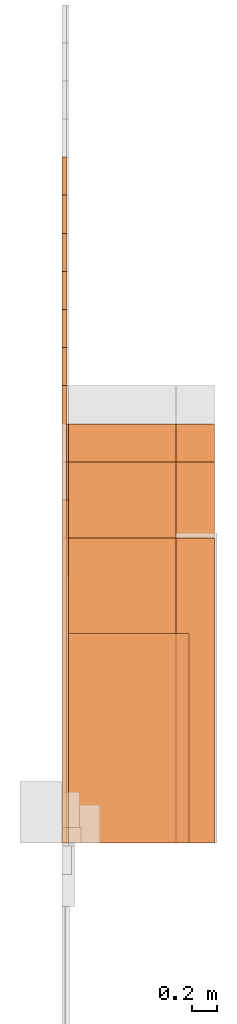
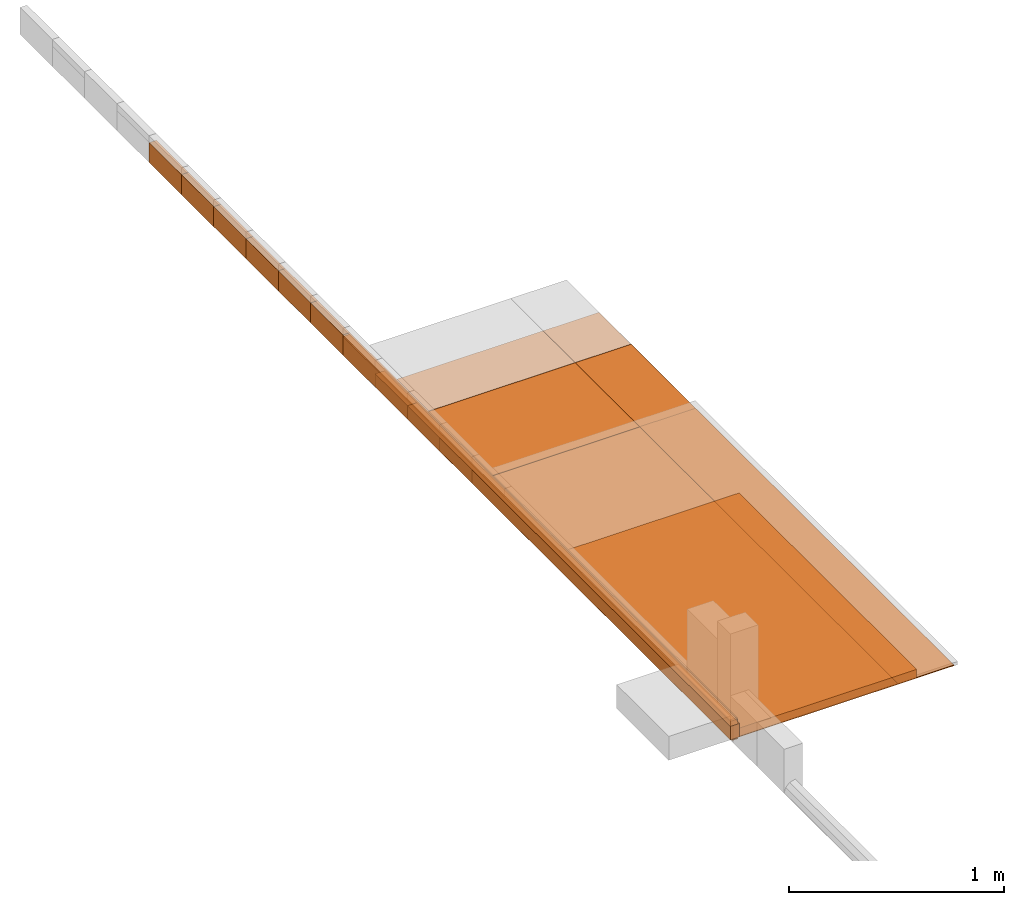
# Not in any storey, part 2 of 5: 26 proxies.
"""IFC4 model written with IfcOpenShell, lengths in metres."""

from ifc_helpers import new_model, entity, si_unit, converted_unit, direction, origin_with_axes, place, context, subcontext, project, faceted_brep, element, save


model = new_model("IFC4")

# Units and contexts
model_context = context("Model", 3, precision=1e-05, world=origin_with_axes(), true_north=direction((0.0, 1.0)))
body_context = subcontext(model_context, "Body", "Model", "MODEL_VIEW")
ifc_project = project(units=[si_unit("LENGTHUNIT", "METRE"), si_unit("AREAUNIT", "SQUARE_METRE"), si_unit("VOLUMEUNIT", "CUBIC_METRE"), converted_unit("PLANEANGLEUNIT", "DEGREE", entity("IfcPlaneAngleMeasure", 0.017453292519943295), si_unit("PLANEANGLEUNIT", "RADIAN"), dimensions=[0, 0, 0, 0, 0, 0, 0])], contexts=[model_context])

# Proxies
proxy_1_placement = place(None, origin_with_axes())
element("IfcBuildingElementProxy", 1, at=proxy_1_placement, Name="Timber 114x38x3600", context=body_context, shape_type="Brep", body=[
    faceted_brep([(0.0, 3.6, 0.0), (0.0, 3.6, 0.114), (0.038, 3.6, 0.114), (0.038, 3.6, 0.0), (0.038, 3.6, 0.0), (0.038, 3.6, 0.114), (0.038, 0.0, 0.114), (0.038, 0.0, 0.0), (0.038, 0.0, 0.0), (0.038, 0.0, 0.114), (0.0, 0.0, 0.114), (0.0, 0.0, 0.0), (0.0, 0.0, 0.0), (0.0, 0.0, 0.114), (0.0, 3.6, 0.114), (0.0, 3.6, 0.0), (0.038, 0.0, 0.0), (0.0, 0.0, 0.0), (0.0, 3.6, 0.0), (0.038, 3.6, 0.0), (0.038, 3.6, 0.114), (0.0, 3.6, 0.114), (0.0, 0.0, 0.114), (0.038, 0.0, 0.114)], [[[0, 1, 2, 3]], [[4, 5, 6, 7]], [[8, 9, 10, 11]], [[12, 13, 14, 15]], [[16, 17, 18, 19]], [[20, 21, 22, 23]]]),
])
proxy_2_placement = place(None, origin_with_axes())
element("IfcBuildingElementProxy", 2, at=proxy_2_placement, Name="Timber 114x38x3900", context=body_context, shape_type="Brep", body=[
    faceted_brep([(0.038, 0.0, 0.0), (0.038, 0.0, 0.114), (0.0, 0.0, 0.114), (0.0, 0.0, 0.0), (0.038, 3.9, 0.0), (0.038, 3.9, 0.114), (0.038, 0.0, 0.114), (0.038, 0.0, 0.0), (0.0, 3.9, 0.0), (0.0, 3.9, 0.114), (0.038, 3.9, 0.114), (0.038, 3.9, 0.0), (0.0, 0.0, 0.0), (0.0, 0.0, 0.114), (0.0, 3.9, 0.114), (0.0, 3.9, 0.0), (0.0, 3.9, 0.0), (0.038, 3.9, 0.0), (0.038, 0.0, 0.0), (0.0, 0.0, 0.0), (0.0, 0.0, 0.114), (0.038, 0.0, 0.114), (0.038, 3.9, 0.114), (0.0, 3.9, 0.114)], [[[0, 1, 2, 3]], [[4, 5, 6, 7]], [[8, 9, 10, 11]], [[12, 13, 14, 15]], [[16, 17, 18, 19]], [[20, 21, 22, 23]]]),
])
proxy_3_placement = place(None, origin_with_axes())
element("IfcBuildingElementProxy", 3, at=proxy_3_placement, Name="Timber 114x38x4200", context=body_context, shape_type="Brep", body=[
    faceted_brep([(0.0, 4.2, 0.0), (0.0, 4.2, 0.114), (0.038, 4.2, 0.114), (0.038, 4.2, 0.0), (0.038, 4.2, 0.0), (0.038, 4.2, 0.114), (0.038, 0.0, 0.114), (0.038, 0.0, 0.0), (0.038, 0.0, 0.0), (0.038, 0.0, 0.114), (0.0, 0.0, 0.114), (0.0, 0.0, 0.0), (0.0, 0.0, 0.0), (0.0, 0.0, 0.114), (0.0, 4.2, 0.114), (0.0, 4.2, 0.0), (0.038, 0.0, 0.0), (0.0, 0.0, 0.0), (0.0, 4.2, 0.0), (0.038, 4.2, 0.0), (0.038, 4.2, 0.114), (0.0, 4.2, 0.114), (0.0, 0.0, 0.114), (0.038, 0.0, 0.114)], [[[0, 1, 2, 3]], [[4, 5, 6, 7]], [[8, 9, 10, 11]], [[12, 13, 14, 15]], [[16, 17, 18, 19]], [[20, 21, 22, 23]]]),
])
proxy_4_placement = place(None, origin_with_axes())
element("IfcBuildingElementProxy", 4, at=proxy_4_placement, Name="Timber 114x38x4500", context=body_context, shape_type="Brep", body=[
    faceted_brep([(0.038, 0.0, 0.0), (0.038, 0.0, 0.114), (0.0, 0.0, 0.114), (0.0, 0.0, 0.0), (0.038, 4.5, 0.0), (0.038, 4.5, 0.114), (0.038, 0.0, 0.114), (0.038, 0.0, 0.0), (0.0, 4.5, 0.0), (0.0, 4.5, 0.114), (0.038, 4.5, 0.114), (0.038, 4.5, 0.0), (0.0, 0.0, 0.0), (0.0, 0.0, 0.114), (0.0, 4.5, 0.114), (0.0, 4.5, 0.0), (0.0, 4.5, 0.0), (0.038, 4.5, 0.0), (0.038, 0.0, 0.0), (0.0, 0.0, 0.0), (0.0, 0.0, 0.114), (0.038, 0.0, 0.114), (0.038, 4.5, 0.114), (0.0, 4.5, 0.114)], [[[0, 1, 2, 3]], [[4, 5, 6, 7]], [[8, 9, 10, 11]], [[12, 13, 14, 15]], [[16, 17, 18, 19]], [[20, 21, 22, 23]]]),
])
proxy_5_placement = place(None, origin_with_axes())
element("IfcBuildingElementProxy", 5, at=proxy_5_placement, Name="Timber 114x38x4800", context=body_context, shape_type="Brep", body=[
    faceted_brep([(0.038, 0.0, 0.0), (0.038, 0.0, 0.114), (0.0, 0.0, 0.114), (0.0, 0.0, 0.0), (0.038, 4.8, 0.0), (0.038, 4.8, 0.114), (0.038, 0.0, 0.114), (0.038, 0.0, 0.0), (0.0, 4.8, 0.0), (0.0, 4.8, 0.114), (0.038, 4.8, 0.114), (0.038, 4.8, 0.0), (0.0, 0.0, 0.0), (0.0, 0.0, 0.114), (0.0, 4.8, 0.114), (0.0, 4.8, 0.0), (0.0, 4.8, 0.0), (0.038, 4.8, 0.0), (0.038, 0.0, 0.0), (0.0, 0.0, 0.0), (0.0, 0.0, 0.114), (0.038, 0.0, 0.114), (0.038, 4.8, 0.114), (0.0, 4.8, 0.114)], [[[0, 1, 2, 3]], [[4, 5, 6, 7]], [[8, 9, 10, 11]], [[12, 13, 14, 15]], [[16, 17, 18, 19]], [[20, 21, 22, 23]]]),
])
proxy_6_placement = place(None, origin_with_axes())
element("IfcBuildingElementProxy", 6, at=proxy_6_placement, Name="Timber 114x38x5100", context=body_context, shape_type="Brep", body=[
    faceted_brep([(0.038, 0.0, 0.0), (0.038, 0.0, 0.114), (0.0, 0.0, 0.114), (0.0, 0.0, 0.0), (0.038, 5.1, 0.0), (0.038, 5.1, 0.114), (0.038, 0.0, 0.114), (0.038, 0.0, 0.0), (0.0, 5.1, 0.0), (0.0, 5.1, 0.114), (0.038, 5.1, 0.114), (0.038, 5.1, 0.0), (0.0, 0.0, 0.0), (0.0, 0.0, 0.114), (0.0, 5.1, 0.114), (0.0, 5.1, 0.0), (0.0, 5.1, 0.0), (0.038, 5.1, 0.0), (0.038, 0.0, 0.0), (0.0, 0.0, 0.0), (0.0, 0.0, 0.114), (0.038, 0.0, 0.114), (0.038, 5.1, 0.114), (0.0, 5.1, 0.114)], [[[0, 1, 2, 3]], [[4, 5, 6, 7]], [[8, 9, 10, 11]], [[12, 13, 14, 15]], [[16, 17, 18, 19]], [[20, 21, 22, 23]]]),
])
proxy_7_placement = place(None, origin_with_axes())
element("IfcBuildingElementProxy", 7, at=proxy_7_placement, Name="Timber 114x38x5400", context=body_context, shape_type="Brep", body=[
    faceted_brep([(0.038, 0.0, 0.0), (0.038, 0.0, 0.114), (0.0, 0.0, 0.114), (0.0, 0.0, 0.0), (0.038, 5.4, 0.0), (0.038, 5.4, 0.114), (0.038, 0.0, 0.114), (0.038, 0.0, 0.0), (0.0, 5.4, 0.0), (0.0, 5.4, 0.114), (0.038, 5.4, 0.114), (0.038, 5.4, 0.0), (0.0, 0.0, 0.0), (0.0, 0.0, 0.114), (0.0, 5.4, 0.114), (0.0, 5.4, 0.0), (0.0, 5.4, 0.0), (0.038, 5.4, 0.0), (0.038, 0.0, 0.0), (0.0, 0.0, 0.0), (0.0, 0.0, 0.114), (0.038, 0.0, 0.114), (0.038, 5.4, 0.114), (0.0, 5.4, 0.114)], [[[0, 1, 2, 3]], [[4, 5, 6, 7]], [[8, 9, 10, 11]], [[12, 13, 14, 15]], [[16, 17, 18, 19]], [[20, 21, 22, 23]]]),
])
proxy_8_placement = place(None, origin_with_axes())
element("IfcBuildingElementProxy", 8, at=proxy_8_placement, Name="Timber 38x105x3600", context=body_context, shape_type="Brep", body=[
    faceted_brep([(0.0, 3.6, 0.0), (0.0, 3.6, 0.105), (0.038, 3.6, 0.105), (0.038, 3.6, 0.0), (0.038, 3.6, 0.0), (0.038, 3.6, 0.105), (0.038, 0.0, 0.105), (0.038, 0.0, 0.0), (0.038, 0.0, 0.0), (0.038, 0.0, 0.105), (0.0, 0.0, 0.105), (0.0, 0.0, 0.0), (0.0, 0.0, 0.0), (0.0, 0.0, 0.105), (0.0, 3.6, 0.105), (0.0, 3.6, 0.0), (0.038, 0.0, 0.0), (0.0, 0.0, 0.0), (0.0, 3.6, 0.0), (0.038, 3.6, 0.0), (0.038, 3.6, 0.105), (0.0, 3.6, 0.105), (0.0, 0.0, 0.105), (0.038, 0.0, 0.105)], [[[0, 1, 2, 3]], [[4, 5, 6, 7]], [[8, 9, 10, 11]], [[12, 13, 14, 15]], [[16, 17, 18, 19]], [[20, 21, 22, 23]]]),
])
proxy_9_placement = place(None, origin_with_axes())
element("IfcBuildingElementProxy", 9, at=proxy_9_placement, Name="Timber 50x76x2400", context=body_context, shape_type="Brep", body=[
    faceted_brep([(0.0, 2.4, 0.0), (0.0, 2.4, 0.076), (0.05, 2.4, 0.076), (0.05, 2.4, 0.0), (0.05, 2.4, 0.0), (0.05, 2.4, 0.076), (0.05, 0.0, 0.076), (0.05, 0.0, 0.0), (0.05, 0.0, 0.0), (0.05, 0.0, 0.076), (0.0, 0.0, 0.076), (0.0, 0.0, 0.0), (0.0, 0.0, 0.0), (0.0, 0.0, 0.076), (0.0, 2.4, 0.076), (0.0, 2.4, 0.0), (0.05, 0.0, 0.0), (0.0, 0.0, 0.0), (0.0, 2.4, 0.0), (0.05, 2.4, 0.0), (0.05, 2.4, 0.076), (0.0, 2.4, 0.076), (0.0, 0.0, 0.076), (0.05, 0.0, 0.076)], [[[0, 1, 2, 3]], [[4, 5, 6, 7]], [[8, 9, 10, 11]], [[12, 13, 14, 15]], [[16, 17, 18, 19]], [[20, 21, 22, 23]]]),
])
proxy_10_placement = place(None, origin_with_axes())
element("IfcBuildingElementProxy", 10, at=proxy_10_placement, Name="Timber 50x76x2700", context=body_context, shape_type="Brep", body=[
    faceted_brep([(0.0, 2.7, 0.0), (0.0, 2.7, 0.076), (0.05, 2.7, 0.076), (0.05, 2.7, 0.0), (0.05, 2.7, 0.0), (0.05, 2.7, 0.076), (0.05, 0.0, 0.076), (0.05, 0.0, 0.0), (0.05, 0.0, 0.0), (0.05, 0.0, 0.076), (0.0, 0.0, 0.076), (0.0, 0.0, 0.0), (0.0, 0.0, 0.0), (0.0, 0.0, 0.076), (0.0, 2.7, 0.076), (0.0, 2.7, 0.0), (0.05, 0.0, 0.0), (0.0, 0.0, 0.0), (0.0, 2.7, 0.0), (0.05, 2.7, 0.0), (0.05, 2.7, 0.076), (0.0, 2.7, 0.076), (0.0, 0.0, 0.076), (0.05, 0.0, 0.076)], [[[0, 1, 2, 3]], [[4, 5, 6, 7]], [[8, 9, 10, 11]], [[12, 13, 14, 15]], [[16, 17, 18, 19]], [[20, 21, 22, 23]]]),
])
proxy_11_placement = place(None, origin_with_axes())
element("IfcBuildingElementProxy", 11, at=proxy_11_placement, Name="Timber 50x76x3000", context=body_context, shape_type="Brep", body=[
    faceted_brep([(0.0, 3.0, 0.0), (0.0, 3.0, 0.076), (0.05, 3.0, 0.076), (0.05, 3.0, 0.0), (0.05, 3.0, 0.0), (0.05, 3.0, 0.076), (0.05, 0.0, 0.076), (0.05, 0.0, 0.0), (0.05, 0.0, 0.0), (0.05, 0.0, 0.076), (0.0, 0.0, 0.076), (0.0, 0.0, 0.0), (0.0, 0.0, 0.0), (0.0, 0.0, 0.076), (0.0, 3.0, 0.076), (0.0, 3.0, 0.0), (0.05, 0.0, 0.0), (0.0, 0.0, 0.0), (0.0, 3.0, 0.0), (0.05, 3.0, 0.0), (0.05, 3.0, 0.076), (0.0, 3.0, 0.076), (0.0, 0.0, 0.076), (0.05, 0.0, 0.076)], [[[0, 1, 2, 3]], [[4, 5, 6, 7]], [[8, 9, 10, 11]], [[12, 13, 14, 15]], [[16, 17, 18, 19]], [[20, 21, 22, 23]]]),
])
proxy_12_placement = place(None, origin_with_axes())
element("IfcBuildingElementProxy", 12, at=proxy_12_placement, Name="Timber 50x76x3300", context=body_context, shape_type="Brep", body=[
    faceted_brep([(0.05, 0.0, 0.0), (0.05, 0.0, 0.076), (0.0, 0.0, 0.076), (0.0, 0.0, 0.0), (0.05, 3.3, 0.0), (0.05, 3.3, 0.076), (0.05, 0.0, 0.076), (0.05, 0.0, 0.0), (0.0, 3.3, 0.0), (0.0, 3.3, 0.076), (0.05, 3.3, 0.076), (0.05, 3.3, 0.0), (0.0, 0.0, 0.0), (0.0, 0.0, 0.076), (0.0, 3.3, 0.076), (0.0, 3.3, 0.0), (0.0, 3.3, 0.0), (0.05, 3.3, 0.0), (0.05, 0.0, 0.0), (0.0, 0.0, 0.0), (0.0, 0.0, 0.076), (0.05, 0.0, 0.076), (0.05, 3.3, 0.076), (0.0, 3.3, 0.076)], [[[0, 1, 2, 3]], [[4, 5, 6, 7]], [[8, 9, 10, 11]], [[12, 13, 14, 15]], [[16, 17, 18, 19]], [[20, 21, 22, 23]]]),
])
proxy_13_placement = place(None, origin_with_axes())
element("IfcBuildingElementProxy", 13, at=proxy_13_placement, Name="900x2400x4", context=body_context, shape_type="Brep", body=[
    faceted_brep([(0.9, 0.0, 0.0), (0.9, 0.0, 0.004), (0.0, 0.0, 0.004), (0.0, 0.0, 0.0), (0.9, 2.4, 0.0), (0.9, 2.4, 0.004), (0.9, 0.0, 0.004), (0.9, 0.0, 0.0), (0.0, 2.4, 0.0), (0.0, 2.4, 0.004), (0.9, 2.4, 0.004), (0.9, 2.4, 0.0), (0.0, 0.0, 0.0), (0.0, 0.0, 0.004), (0.0, 2.4, 0.004), (0.0, 2.4, 0.0), (0.0, 2.4, 0.0), (0.9, 2.4, 0.0), (0.9, 0.0, 0.0), (0.0, 0.0, 0.0), (0.0, 0.0, 0.004), (0.9, 0.0, 0.004), (0.9, 2.4, 0.004), (0.0, 2.4, 0.004)], [[[0, 1, 2, 3]], [[4, 5, 6, 7]], [[8, 9, 10, 11]], [[12, 13, 14, 15]], [[16, 17, 18, 19]], [[20, 21, 22, 23]]]),
])
proxy_14_placement = place(None, origin_with_axes())
element("IfcBuildingElementProxy", 14, at=proxy_14_placement, Name="900x3000x4", context=body_context, shape_type="Brep", body=[
    faceted_brep([(0.9, 0.0, 0.0), (0.9, 0.0, 0.004), (0.0, 0.0, 0.004), (0.0, 0.0, 0.0), (0.9, 3.0, 0.0), (0.9, 3.0, 0.004), (0.9, 0.0, 0.004), (0.9, 0.0, 0.0), (0.0, 3.0, 0.0), (0.0, 3.0, 0.004), (0.9, 3.0, 0.004), (0.9, 3.0, 0.0), (0.0, 0.0, 0.0), (0.0, 0.0, 0.004), (0.0, 3.0, 0.004), (0.0, 3.0, 0.0), (0.0, 3.0, 0.0), (0.9, 3.0, 0.0), (0.9, 0.0, 0.0), (0.0, 0.0, 0.0), (0.0, 0.0, 0.004), (0.9, 0.0, 0.004), (0.9, 3.0, 0.004), (0.0, 3.0, 0.004)], [[[0, 1, 2, 3]], [[4, 5, 6, 7]], [[8, 9, 10, 11]], [[12, 13, 14, 15]], [[16, 17, 18, 19]], [[20, 21, 22, 23]]]),
])
proxy_15_placement = place(None, origin_with_axes())
element("IfcBuildingElementProxy", 15, at=proxy_15_placement, Name="900x3300x4", context=body_context, shape_type="Brep", body=[
    faceted_brep([(0.9, 0.0, 0.0), (0.9, 0.0, 0.004), (0.0, 0.0, 0.004), (0.0, 0.0, 0.0), (0.9, 3.3, 0.0), (0.9, 3.3, 0.004), (0.9, 0.0, 0.004), (0.9, 0.0, 0.0), (0.0, 3.3, 0.0), (0.0, 3.3, 0.004), (0.9, 3.3, 0.004), (0.9, 3.3, 0.0), (0.0, 0.0, 0.0), (0.0, 0.0, 0.004), (0.0, 3.3, 0.004), (0.0, 3.3, 0.0), (0.0, 3.3, 0.0), (0.9, 3.3, 0.0), (0.9, 0.0, 0.0), (0.0, 0.0, 0.0), (0.0, 0.0, 0.004), (0.9, 0.0, 0.004), (0.9, 3.3, 0.004), (0.0, 3.3, 0.004)], [[[0, 1, 2, 3]], [[4, 5, 6, 7]], [[8, 9, 10, 11]], [[12, 13, 14, 15]], [[16, 17, 18, 19]], [[20, 21, 22, 23]]]),
])
proxy_16_placement = place(None, origin_with_axes())
element("IfcBuildingElementProxy", 16, at=proxy_16_placement, Name="1200x2400x4", context=body_context, shape_type="Brep", body=[
    faceted_brep([(1.2, 0.0, 0.0), (1.2, 0.0, 0.004), (0.0, 0.0, 0.004), (0.0, 0.0, 0.0), (1.2, 2.4, 0.0), (1.2, 2.4, 0.004), (1.2, 0.0, 0.004), (1.2, 0.0, 0.0), (0.0, 2.4, 0.0), (0.0, 2.4, 0.004), (1.2, 2.4, 0.004), (1.2, 2.4, 0.0), (0.0, 0.0, 0.0), (0.0, 0.0, 0.004), (0.0, 2.4, 0.004), (0.0, 2.4, 0.0), (0.0, 2.4, 0.0), (1.2, 2.4, 0.0), (1.2, 0.0, 0.0), (0.0, 0.0, 0.0), (0.0, 0.0, 0.004), (1.2, 0.0, 0.004), (1.2, 2.4, 0.004), (0.0, 2.4, 0.004)], [[[0, 1, 2, 3]], [[4, 5, 6, 7]], [[8, 9, 10, 11]], [[12, 13, 14, 15]], [[16, 17, 18, 19]], [[20, 21, 22, 23]]]),
])
proxy_17_placement = place(None, origin_with_axes())
element("IfcBuildingElementProxy", 17, at=proxy_17_placement, Name="1200x3000x4", context=body_context, shape_type="Brep", body=[
    faceted_brep([(1.2, 0.0, 0.0), (1.2, 0.0, 0.004), (0.0, 0.0, 0.004), (0.0, 0.0, 0.0), (1.2, 3.0, 0.0), (1.2, 3.0, 0.004), (1.2, 0.0, 0.004), (1.2, 0.0, 0.0), (0.0, 3.0, 0.0), (0.0, 3.0, 0.004), (1.2, 3.0, 0.004), (1.2, 3.0, 0.0), (0.0, 0.0, 0.0), (0.0, 0.0, 0.004), (0.0, 3.0, 0.004), (0.0, 3.0, 0.0), (0.0, 3.0, 0.0), (1.2, 3.0, 0.0), (1.2, 0.0, 0.0), (0.0, 0.0, 0.0), (0.0, 0.0, 0.004), (1.2, 0.0, 0.004), (1.2, 3.0, 0.004), (0.0, 3.0, 0.004)], [[[0, 1, 2, 3]], [[4, 5, 6, 7]], [[8, 9, 10, 11]], [[12, 13, 14, 15]], [[16, 17, 18, 19]], [[20, 21, 22, 23]]]),
])
proxy_18_placement = place(None, origin_with_axes())
element("IfcBuildingElementProxy", 18, at=proxy_18_placement, Name="1200x3300x4", context=body_context, shape_type="Brep", body=[
    faceted_brep([(1.2, 0.0, 0.0), (1.2, 0.0, 0.004), (0.0, 0.0, 0.004), (0.0, 0.0, 0.0), (1.2, 3.3, 0.0), (1.2, 3.3, 0.004), (1.2, 0.0, 0.004), (1.2, 0.0, 0.0), (0.0, 3.3, 0.0), (0.0, 3.3, 0.004), (1.2, 3.3, 0.004), (1.2, 3.3, 0.0), (0.0, 0.0, 0.0), (0.0, 0.0, 0.004), (0.0, 3.3, 0.004), (0.0, 3.3, 0.0), (0.0, 3.3, 0.0), (1.2, 3.3, 0.0), (1.2, 0.0, 0.0), (0.0, 0.0, 0.0), (0.0, 0.0, 0.004), (1.2, 0.0, 0.004), (1.2, 3.3, 0.004), (0.0, 3.3, 0.004)], [[[0, 1, 2, 3]], [[4, 5, 6, 7]], [[8, 9, 10, 11]], [[12, 13, 14, 15]], [[16, 17, 18, 19]], [[20, 21, 22, 23]]]),
])
proxy_19_placement = place(None, origin_with_axes())
element("IfcBuildingElementProxy", 19, at=proxy_19_placement, Name="900x3000x6", context=body_context, shape_type="Brep", body=[
    faceted_brep([(0.9, 0.0, 0.0), (0.9, 0.0, 0.006), (0.0, 0.0, 0.006), (0.0, 0.0, 0.0), (0.9, 3.0, 0.0), (0.9, 3.0, 0.006), (0.9, 0.0, 0.006), (0.9, 0.0, 0.0), (0.0, 3.0, 0.0), (0.0, 3.0, 0.006), (0.9, 3.0, 0.006), (0.9, 3.0, 0.0), (0.0, 0.0, 0.0), (0.0, 0.0, 0.006), (0.0, 3.0, 0.006), (0.0, 3.0, 0.0), (0.0, 3.0, 0.0), (0.9, 3.0, 0.0), (0.9, 0.0, 0.0), (0.0, 0.0, 0.0), (0.0, 0.0, 0.006), (0.9, 0.0, 0.006), (0.9, 3.0, 0.006), (0.0, 3.0, 0.006)], [[[0, 1, 2, 3]], [[4, 5, 6, 7]], [[8, 9, 10, 11]], [[12, 13, 14, 15]], [[16, 17, 18, 19]], [[20, 21, 22, 23]]]),
])
proxy_20_placement = place(None, origin_with_axes())
element("IfcBuildingElementProxy", 20, at=proxy_20_placement, Name="900x2400x6", context=body_context, shape_type="Brep", body=[
    faceted_brep([(0.9, 0.0, 0.0), (0.9, 0.0, 0.006), (0.0, 0.0, 0.006), (0.0, 0.0, 0.0), (0.9, 2.4, 0.0), (0.9, 2.4, 0.006), (0.9, 0.0, 0.006), (0.9, 0.0, 0.0), (0.0, 2.4, 0.0), (0.0, 2.4, 0.006), (0.9, 2.4, 0.006), (0.9, 2.4, 0.0), (0.0, 0.0, 0.0), (0.0, 0.0, 0.006), (0.0, 2.4, 0.006), (0.0, 2.4, 0.0), (0.0, 2.4, 0.0), (0.9, 2.4, 0.0), (0.9, 0.0, 0.0), (0.0, 0.0, 0.0), (0.0, 0.0, 0.006), (0.9, 0.0, 0.006), (0.9, 2.4, 0.006), (0.0, 2.4, 0.006)], [[[0, 1, 2, 3]], [[4, 5, 6, 7]], [[8, 9, 10, 11]], [[12, 13, 14, 15]], [[16, 17, 18, 19]], [[20, 21, 22, 23]]]),
])
proxy_21_placement = place(None, origin_with_axes())
element("IfcBuildingElementProxy", 21, at=proxy_21_placement, Name="1200x2400x6", context=body_context, shape_type="Brep", body=[
    faceted_brep([(1.2, 0.0, 0.0), (1.2, 0.0, 0.006), (0.0, 0.0, 0.006), (0.0, 0.0, 0.0), (1.2, 2.4, 0.0), (1.2, 2.4, 0.006), (1.2, 0.0, 0.006), (1.2, 0.0, 0.0), (0.0, 2.4, 0.0), (0.0, 2.4, 0.006), (1.2, 2.4, 0.006), (1.2, 2.4, 0.0), (0.0, 0.0, 0.0), (0.0, 0.0, 0.006), (0.0, 2.4, 0.006), (0.0, 2.4, 0.0), (0.0, 2.4, 0.0), (1.2, 2.4, 0.0), (1.2, 0.0, 0.0), (0.0, 0.0, 0.0), (0.0, 0.0, 0.006), (1.2, 0.0, 0.006), (1.2, 2.4, 0.006), (0.0, 2.4, 0.006)], [[[0, 1, 2, 3]], [[4, 5, 6, 7]], [[8, 9, 10, 11]], [[12, 13, 14, 15]], [[16, 17, 18, 19]], [[20, 21, 22, 23]]]),
])
proxy_22_placement = place(None, origin_with_axes())
element("IfcBuildingElementProxy", 22, at=proxy_22_placement, Name="1200x3000x6", context=body_context, shape_type="Brep", body=[
    faceted_brep([(1.2, 0.0, 0.0), (1.2, 0.0, 0.006), (0.0, 0.0, 0.006), (0.0, 0.0, 0.0), (1.2, 3.0, 0.0), (1.2, 3.0, 0.006), (1.2, 0.0, 0.006), (1.2, 0.0, 0.0), (0.0, 3.0, 0.0), (0.0, 3.0, 0.006), (1.2, 3.0, 0.006), (1.2, 3.0, 0.0), (0.0, 0.0, 0.0), (0.0, 0.0, 0.006), (0.0, 3.0, 0.006), (0.0, 3.0, 0.0), (0.0, 3.0, 0.0), (1.2, 3.0, 0.0), (1.2, 0.0, 0.0), (0.0, 0.0, 0.0), (0.0, 0.0, 0.006), (1.2, 0.0, 0.006), (1.2, 3.0, 0.006), (0.0, 3.0, 0.006)], [[[0, 1, 2, 3]], [[4, 5, 6, 7]], [[8, 9, 10, 11]], [[12, 13, 14, 15]], [[16, 17, 18, 19]], [[20, 21, 22, 23]]]),
])
proxy_23_placement = place(None, origin_with_axes())
element("IfcBuildingElementProxy", 23, at=proxy_23_placement, Name="Solar panel 1650x1000x5", context=body_context, shape_type="Brep", body=[
    faceted_brep([(1.0, 0.0, 0.0), (1.0, 0.0, 0.05), (0.0, 0.0, 0.05), (0.0, 0.0, 0.0), (1.0, 1.65, 0.0), (1.0, 1.65, 0.05), (1.0, 0.0, 0.05), (1.0, 0.0, 0.0), (0.0, 1.65, 0.0), (0.0, 1.65, 0.05), (1.0, 1.65, 0.05), (1.0, 1.65, 0.0), (0.0, 0.0, 0.0), (0.0, 0.0, 0.05), (0.0, 1.65, 0.05), (0.0, 1.65, 0.0), (0.0, 1.65, 0.0), (1.0, 1.65, 0.0), (1.0, 0.0, 0.0), (0.0, 0.0, 0.0), (0.0, 0.0, 0.05), (1.0, 0.0, 0.05), (1.0, 1.65, 0.05), (0.0, 1.65, 0.05)], [[[0, 1, 2, 3]], [[4, 5, 6, 7]], [[8, 9, 10, 11]], [[12, 13, 14, 15]], [[16, 17, 18, 19]], [[20, 21, 22, 23]]]),
])
proxy_24_placement = place(None, origin_with_axes())
element("IfcBuildingElementProxy", 24, at=proxy_24_placement, Name="Strip 4x2700", context=body_context, shape_type="Brep", body=[
    faceted_brep([(0.025, 0.0, 0.0), (0.025, 2.7, 5.99520433297585e-16), (0.0, 2.7, 5.99520433297585e-16), (0.0, 0.0, 0.0), (0.025, 1.02140518265514e-18, -0.0046), (0.025, 2.7, -0.0045999999999994), (0.025, 2.7, 5.99520433297585e-16), (0.025, 0.0, 0.0), (0.01055, 1.02140518265514e-18, -0.0046), (0.01055, 2.7, -0.0045999999999994), (0.025, 2.7, -0.0045999999999994), (0.025, 1.02140518265514e-18, -0.0046), (0.01055, 1.13242748511766e-18, -0.0051), (0.01055, 2.7, -0.0050999999999994), (0.01055, 2.7, -0.0045999999999994), (0.01055, 1.02140518265514e-18, -0.0046), (0.03995, 1.13242748511766e-18, -0.0051), (0.03995, 2.7, -0.0050999999999994), (0.01055, 2.7, -0.0050999999999994), (0.01055, 1.13242748511766e-18, -0.0051), (0.03995, 1.02140518265514e-18, -0.0046), (0.03995, 2.7, -0.0045999999999994), (0.03995, 2.7, -0.0050999999999994), (0.03995, 1.13242748511766e-18, -0.0051), (0.0255, 1.02140518265514e-18, -0.0046), (0.0255, 2.7, -0.0045999999999994), (0.03995, 2.7, -0.0045999999999994), (0.03995, 1.02140518265514e-18, -0.0046), (0.0255, 0.0, 0.0), (0.0255, 2.7, 5.99520433297585e-16), (0.0255, 2.7, -0.0045999999999994), (0.0255, 1.02140518265514e-18, -0.0046), (0.0505, 0.0, 0.0), (0.0505, 2.7, 5.99520433297585e-16), (0.0255, 2.7, 5.99520433297585e-16), (0.0255, 0.0, 0.0), (0.0505, 6.66133814775094e-20, -0.0003), (0.0505, 2.7, -0.0002999999999994), (0.0505, 2.7, 5.99520433297585e-16), (0.0505, 0.0, 0.0), (0.0258, 6.66133814775094e-20, -0.0003), (0.0258, 2.7, -0.0002999999999994), (0.0505, 2.7, -0.0002999999999994), (0.0505, 6.66133814775094e-20, -0.0003), (0.0258, 9.54791801177635e-19, -0.0043), (0.0258, 2.7, -0.0042999999999994), (0.0258, 2.7, -0.0002999999999994), (0.0258, 6.66133814775094e-20, -0.0003), (0.04025, 9.54791801177635e-19, -0.0043), (0.04025, 2.7, -0.0042999999999994), (0.0258, 2.7, -0.0042999999999994), (0.0258, 9.54791801177635e-19, -0.0043), (0.04025, 1.19904086659517e-18, -0.0054), (0.04025, 2.7, -0.0053999999999994), (0.04025, 2.7, -0.0042999999999994), (0.04025, 9.54791801177635e-19, -0.0043), (0.01025, 1.19904086659517e-18, -0.0054), (0.01025, 2.7, -0.0053999999999994), (0.04025, 2.7, -0.0053999999999994), (0.04025, 1.19904086659517e-18, -0.0054), (0.01025, 9.54791801177635e-19, -0.0043), (0.01025, 2.7, -0.0042999999999994), (0.01025, 2.7, -0.0053999999999994), (0.01025, 1.19904086659517e-18, -0.0054), (0.0247, 9.54791801177635e-19, -0.0043), (0.0247, 2.7, -0.0042999999999994), (0.01025, 2.7, -0.0042999999999994), (0.01025, 9.54791801177635e-19, -0.0043), (0.0247, 6.66133814775094e-20, -0.0003), (0.0247, 2.7, -0.0002999999999994), (0.0247, 2.7, -0.0042999999999994), (0.0247, 9.54791801177635e-19, -0.0043), (0.0, 6.66133814775094e-20, -0.0003), (0.0, 2.7, -0.0002999999999994), (0.0247, 2.7, -0.0002999999999994), (0.0247, 6.66133814775094e-20, -0.0003), (0.0, 0.0, 0.0), (0.0, 2.7, 5.99520433297585e-16), (0.0, 2.7, -0.0002999999999994), (0.0, 6.66133814775094e-20, -0.0003), (0.0, 6.66133814775094e-20, -0.0003), (0.0247, 6.66133814775094e-20, -0.0003), (0.0247, 9.54791801177635e-19, -0.0043), (0.01025, 9.54791801177635e-19, -0.0043), (0.01025, 1.19904086659517e-18, -0.0054), (0.04025, 1.19904086659517e-18, -0.0054), (0.04025, 9.54791801177635e-19, -0.0043), (0.0258, 9.54791801177635e-19, -0.0043), (0.0258, 6.66133814775094e-20, -0.0003), (0.0505, 6.66133814775094e-20, -0.0003), (0.0505, 0.0, 0.0), (0.0255, 0.0, 0.0), (0.0255, 1.02140518265514e-18, -0.0046), (0.03995, 1.02140518265514e-18, -0.0046), (0.03995, 1.13242748511766e-18, -0.0051), (0.01055, 1.13242748511766e-18, -0.0051), (0.01055, 1.02140518265514e-18, -0.0046), (0.025, 1.02140518265514e-18, -0.0046), (0.025, 0.0, 0.0), (0.0, 0.0, 0.0), (0.0, 2.7, 5.99520433297585e-16), (0.025, 2.7, 5.99520433297585e-16), (0.025, 2.7, -0.0045999999999994), (0.01055, 2.7, -0.0045999999999994), (0.01055, 2.7, -0.0050999999999994), (0.03995, 2.7, -0.0050999999999994), (0.03995, 2.7, -0.0045999999999994), (0.0255, 2.7, -0.0045999999999994), (0.0255, 2.7, 5.99520433297585e-16), (0.0505, 2.7, 5.99520433297585e-16), (0.0505, 2.7, -0.0002999999999994), (0.0258, 2.7, -0.0002999999999994), (0.0258, 2.7, -0.0042999999999994), (0.04025, 2.7, -0.0042999999999994), (0.04025, 2.7, -0.0053999999999994), (0.01025, 2.7, -0.0053999999999994), (0.01025, 2.7, -0.0042999999999994), (0.0247, 2.7, -0.0042999999999994), (0.0247, 2.7, -0.0002999999999994), (0.0, 2.7, -0.0002999999999994)], [[[0, 1, 2, 3]], [[4, 5, 6, 7]], [[8, 9, 10, 11]], [[12, 13, 14, 15]], [[16, 17, 18, 19]], [[20, 21, 22, 23]], [[24, 25, 26, 27]], [[28, 29, 30, 31]], [[32, 33, 34, 35]], [[36, 37, 38, 39]], [[40, 41, 42, 43]], [[44, 45, 46, 47]], [[48, 49, 50, 51]], [[52, 53, 54, 55]], [[56, 57, 58, 59]], [[60, 61, 62, 63]], [[64, 65, 66, 67]], [[68, 69, 70, 71]], [[72, 73, 74, 75]], [[76, 77, 78, 79]], [[80, 81, 82, 83, 84, 85, 86, 87, 88, 89, 90, 91, 92, 93, 94, 95, 96, 97, 98, 99]], [[100, 101, 102, 103, 104, 105, 106, 107, 108, 109, 110, 111, 112, 113, 114, 115, 116, 117, 118, 119]]]),
])
proxy_25_placement = place(None, origin_with_axes())
element("IfcBuildingElementProxy", 25, at=proxy_25_placement, Name="Strip 4x3000", context=body_context, shape_type="Brep", body=[
    faceted_brep([(0.025, 0.0, 0.0), (0.025, 3.0, 6.66133814775094e-16), (0.0, 3.0, 6.66133814775094e-16), (0.0, 0.0, 0.0), (0.025, 1.02140518265514e-18, -0.0046), (0.025, 3.0, -0.00459999999999933), (0.025, 3.0, 6.66133814775094e-16), (0.025, 0.0, 0.0), (0.01055, 1.02140518265514e-18, -0.0046), (0.01055, 3.0, -0.00459999999999933), (0.025, 3.0, -0.00459999999999933), (0.025, 1.02140518265514e-18, -0.0046), (0.01055, 1.13242748511766e-18, -0.0051), (0.01055, 3.0, -0.00509999999999933), (0.01055, 3.0, -0.00459999999999933), (0.01055, 1.02140518265514e-18, -0.0046), (0.03995, 1.13242748511766e-18, -0.0051), (0.03995, 3.0, -0.00509999999999933), (0.01055, 3.0, -0.00509999999999933), (0.01055, 1.13242748511766e-18, -0.0051), (0.03995, 1.02140518265514e-18, -0.0046), (0.03995, 3.0, -0.00459999999999933), (0.03995, 3.0, -0.00509999999999933), (0.03995, 1.13242748511766e-18, -0.0051), (0.0255, 1.02140518265514e-18, -0.0046), (0.0255, 3.0, -0.00459999999999933), (0.03995, 3.0, -0.00459999999999933), (0.03995, 1.02140518265514e-18, -0.0046), (0.0255, 0.0, 0.0), (0.0255, 3.0, 6.66133814775094e-16), (0.0255, 3.0, -0.00459999999999933), (0.0255, 1.02140518265514e-18, -0.0046), (0.0505, 0.0, 0.0), (0.0505, 3.0, 6.66133814775094e-16), (0.0255, 3.0, 6.66133814775094e-16), (0.0255, 0.0, 0.0), (0.0505, 6.66133814775094e-20, -0.0003), (0.0505, 3.0, -0.000299999999999334), (0.0505, 3.0, 6.66133814775094e-16), (0.0505, 0.0, 0.0), (0.0258, 6.66133814775094e-20, -0.0003), (0.0258, 3.0, -0.000299999999999334), (0.0505, 3.0, -0.000299999999999334), (0.0505, 6.66133814775094e-20, -0.0003), (0.0258, 9.54791801177635e-19, -0.0043), (0.0258, 3.0, -0.00429999999999933), (0.0258, 3.0, -0.000299999999999334), (0.0258, 6.66133814775094e-20, -0.0003), (0.04025, 9.54791801177635e-19, -0.0043), (0.04025, 3.0, -0.00429999999999933), (0.0258, 3.0, -0.00429999999999933), (0.0258, 9.54791801177635e-19, -0.0043), (0.04025, 1.19904086659517e-18, -0.0054), (0.04025, 3.0, -0.00539999999999933), (0.04025, 3.0, -0.00429999999999933), (0.04025, 9.54791801177635e-19, -0.0043), (0.01025, 1.19904086659517e-18, -0.0054), (0.01025, 3.0, -0.00539999999999933), (0.04025, 3.0, -0.00539999999999933), (0.04025, 1.19904086659517e-18, -0.0054), (0.01025, 9.54791801177635e-19, -0.0043), (0.01025, 3.0, -0.00429999999999933), (0.01025, 3.0, -0.00539999999999933), (0.01025, 1.19904086659517e-18, -0.0054), (0.0247, 9.54791801177635e-19, -0.0043), (0.0247, 3.0, -0.00429999999999933), (0.01025, 3.0, -0.00429999999999933), (0.01025, 9.54791801177635e-19, -0.0043), (0.0247, 6.66133814775094e-20, -0.0003), (0.0247, 3.0, -0.000299999999999334), (0.0247, 3.0, -0.00429999999999933), (0.0247, 9.54791801177635e-19, -0.0043), (0.0, 6.66133814775094e-20, -0.0003), (0.0, 3.0, -0.000299999999999334), (0.0247, 3.0, -0.000299999999999334), (0.0247, 6.66133814775094e-20, -0.0003), (0.0, 0.0, 0.0), (0.0, 3.0, 6.66133814775094e-16), (0.0, 3.0, -0.000299999999999334), (0.0, 6.66133814775094e-20, -0.0003), (0.0, 6.66133814775094e-20, -0.0003), (0.0247, 6.66133814775094e-20, -0.0003), (0.0247, 9.54791801177635e-19, -0.0043), (0.01025, 9.54791801177635e-19, -0.0043), (0.01025, 1.19904086659517e-18, -0.0054), (0.04025, 1.19904086659517e-18, -0.0054), (0.04025, 9.54791801177635e-19, -0.0043), (0.0258, 9.54791801177635e-19, -0.0043), (0.0258, 6.66133814775094e-20, -0.0003), (0.0505, 6.66133814775094e-20, -0.0003), (0.0505, 0.0, 0.0), (0.0255, 0.0, 0.0), (0.0255, 1.02140518265514e-18, -0.0046), (0.03995, 1.02140518265514e-18, -0.0046), (0.03995, 1.13242748511766e-18, -0.0051), (0.01055, 1.13242748511766e-18, -0.0051), (0.01055, 1.02140518265514e-18, -0.0046), (0.025, 1.02140518265514e-18, -0.0046), (0.025, 0.0, 0.0), (0.0, 0.0, 0.0), (0.0, 3.0, 6.66133814775094e-16), (0.025, 3.0, 6.66133814775094e-16), (0.025, 3.0, -0.00459999999999933), (0.01055, 3.0, -0.00459999999999933), (0.01055, 3.0, -0.00509999999999933), (0.03995, 3.0, -0.00509999999999933), (0.03995, 3.0, -0.00459999999999933), (0.0255, 3.0, -0.00459999999999933), (0.0255, 3.0, 6.66133814775094e-16), (0.0505, 3.0, 6.66133814775094e-16), (0.0505, 3.0, -0.000299999999999334), (0.0258, 3.0, -0.000299999999999334), (0.0258, 3.0, -0.00429999999999933), (0.04025, 3.0, -0.00429999999999933), (0.04025, 3.0, -0.00539999999999933), (0.01025, 3.0, -0.00539999999999933), (0.01025, 3.0, -0.00429999999999933), (0.0247, 3.0, -0.00429999999999933), (0.0247, 3.0, -0.000299999999999334), (0.0, 3.0, -0.000299999999999334)], [[[0, 1, 2, 3]], [[4, 5, 6, 7]], [[8, 9, 10, 11]], [[12, 13, 14, 15]], [[16, 17, 18, 19]], [[20, 21, 22, 23]], [[24, 25, 26, 27]], [[28, 29, 30, 31]], [[32, 33, 34, 35]], [[36, 37, 38, 39]], [[40, 41, 42, 43]], [[44, 45, 46, 47]], [[48, 49, 50, 51]], [[52, 53, 54, 55]], [[56, 57, 58, 59]], [[60, 61, 62, 63]], [[64, 65, 66, 67]], [[68, 69, 70, 71]], [[72, 73, 74, 75]], [[76, 77, 78, 79]], [[80, 81, 82, 83, 84, 85, 86, 87, 88, 89, 90, 91, 92, 93, 94, 95, 96, 97, 98, 99]], [[100, 101, 102, 103, 104, 105, 106, 107, 108, 109, 110, 111, 112, 113, 114, 115, 116, 117, 118, 119]]]),
])
proxy_26_placement = place(None, origin_with_axes())
element("IfcBuildingElementProxy", 26, at=proxy_26_placement, Name="Strip 7x2700", context=body_context, shape_type="Brep", body=[
    faceted_brep([(0.025, 0.0, 0.0), (0.025, 2.7, 5.99520433297585e-16), (0.0, 2.7, 5.99520433297585e-16), (0.0, 0.0, 0.0), (0.025, 1.68753899743024e-18, -0.0076), (0.025, 2.7, -0.0075999999999994), (0.025, 2.7, 5.99520433297585e-16), (0.025, 0.0, 0.0), (0.01055, 1.68753899743024e-18, -0.0076), (0.01055, 2.7, -0.0075999999999994), (0.025, 2.7, -0.0075999999999994), (0.025, 1.68753899743024e-18, -0.0076), (0.01055, 1.79856129989275e-18, -0.0081), (0.01055, 2.7, -0.0080999999999994), (0.01055, 2.7, -0.0075999999999994), (0.01055, 1.68753899743024e-18, -0.0076), (0.03995, 1.79856129989275e-18, -0.0081), (0.03995, 2.7, -0.0080999999999994), (0.01055, 2.7, -0.0080999999999994), (0.01055, 1.79856129989275e-18, -0.0081), (0.03995, 1.68753899743024e-18, -0.0076), (0.03995, 2.7, -0.0075999999999994), (0.03995, 2.7, -0.0080999999999994), (0.03995, 1.79856129989275e-18, -0.0081), (0.0255, 1.68753899743024e-18, -0.0076), (0.0255, 2.7, -0.0075999999999994), (0.03995, 2.7, -0.0075999999999994), (0.03995, 1.68753899743024e-18, -0.0076), (0.0255, 0.0, 0.0), (0.0255, 2.7, 5.99520433297585e-16), (0.0255, 2.7, -0.0075999999999994), (0.0255, 1.68753899743024e-18, -0.0076), (0.0505, 0.0, 0.0), (0.0505, 2.7, 5.99520433297585e-16), (0.0255, 2.7, 5.99520433297585e-16), (0.0255, 0.0, 0.0), (0.0505, 6.66133814775094e-20, -0.0003), (0.0505, 2.7, -0.0002999999999994), (0.0505, 2.7, 5.99520433297585e-16), (0.0505, 0.0, 0.0), (0.0258, 6.66133814775094e-20, -0.0003), (0.0258, 2.7, -0.0002999999999994), (0.0505, 2.7, -0.0002999999999994), (0.0505, 6.66133814775094e-20, -0.0003), (0.0258, 1.62092561595273e-18, -0.0073), (0.0258, 2.7, -0.0072999999999994), (0.0258, 2.7, -0.0002999999999994), (0.0258, 6.66133814775094e-20, -0.0003), (0.04025, 1.62092561595273e-18, -0.0073), (0.04025, 2.7, -0.0072999999999994), (0.0258, 2.7, -0.0072999999999994), (0.0258, 1.62092561595273e-18, -0.0073), (0.04025, 1.86517468137026e-18, -0.0084), (0.04025, 2.7, -0.0083999999999994), (0.04025, 2.7, -0.0072999999999994), (0.04025, 1.62092561595273e-18, -0.0073), (0.01025, 1.86517468137026e-18, -0.0084), (0.01025, 2.7, -0.0083999999999994), (0.04025, 2.7, -0.0083999999999994), (0.04025, 1.86517468137026e-18, -0.0084), (0.01025, 1.62092561595273e-18, -0.0073), (0.01025, 2.7, -0.0072999999999994), (0.01025, 2.7, -0.0083999999999994), (0.01025, 1.86517468137026e-18, -0.0084), (0.0247, 1.62092561595273e-18, -0.0073), (0.0247, 2.7, -0.0072999999999994), (0.01025, 2.7, -0.0072999999999994), (0.01025, 1.62092561595273e-18, -0.0073), (0.0247, 6.66133814775094e-20, -0.0003), (0.0247, 2.7, -0.0002999999999994), (0.0247, 2.7, -0.0072999999999994), (0.0247, 1.62092561595273e-18, -0.0073), (0.0, 6.66133814775094e-20, -0.0003), (0.0, 2.7, -0.0002999999999994), (0.0247, 2.7, -0.0002999999999994), (0.0247, 6.66133814775094e-20, -0.0003), (0.0, 0.0, 0.0), (0.0, 2.7, 5.99520433297585e-16), (0.0, 2.7, -0.0002999999999994), (0.0, 6.66133814775094e-20, -0.0003), (0.0, 6.66133814775094e-20, -0.0003), (0.0247, 6.66133814775094e-20, -0.0003), (0.0247, 1.62092561595273e-18, -0.0073), (0.01025, 1.62092561595273e-18, -0.0073), (0.01025, 1.86517468137026e-18, -0.0084), (0.04025, 1.86517468137026e-18, -0.0084), (0.04025, 1.62092561595273e-18, -0.0073), (0.0258, 1.62092561595273e-18, -0.0073), (0.0258, 6.66133814775094e-20, -0.0003), (0.0505, 6.66133814775094e-20, -0.0003), (0.0505, 0.0, 0.0), (0.0255, 0.0, 0.0), (0.0255, 1.68753899743024e-18, -0.0076), (0.03995, 1.68753899743024e-18, -0.0076), (0.03995, 1.79856129989275e-18, -0.0081), (0.01055, 1.79856129989275e-18, -0.0081), (0.01055, 1.68753899743024e-18, -0.0076), (0.025, 1.68753899743024e-18, -0.0076), (0.025, 0.0, 0.0), (0.0, 0.0, 0.0), (0.0, 2.7, 5.99520433297585e-16), (0.025, 2.7, 5.99520433297585e-16), (0.025, 2.7, -0.0075999999999994), (0.01055, 2.7, -0.0075999999999994), (0.01055, 2.7, -0.0080999999999994), (0.03995, 2.7, -0.0080999999999994), (0.03995, 2.7, -0.0075999999999994), (0.0255, 2.7, -0.0075999999999994), (0.0255, 2.7, 5.99520433297585e-16), (0.0505, 2.7, 5.99520433297585e-16), (0.0505, 2.7, -0.0002999999999994), (0.0258, 2.7, -0.0002999999999994), (0.0258, 2.7, -0.0072999999999994), (0.04025, 2.7, -0.0072999999999994), (0.04025, 2.7, -0.0083999999999994), (0.01025, 2.7, -0.0083999999999994), (0.01025, 2.7, -0.0072999999999994), (0.0247, 2.7, -0.0072999999999994), (0.0247, 2.7, -0.0002999999999994), (0.0, 2.7, -0.0002999999999994)], [[[0, 1, 2, 3]], [[4, 5, 6, 7]], [[8, 9, 10, 11]], [[12, 13, 14, 15]], [[16, 17, 18, 19]], [[20, 21, 22, 23]], [[24, 25, 26, 27]], [[28, 29, 30, 31]], [[32, 33, 34, 35]], [[36, 37, 38, 39]], [[40, 41, 42, 43]], [[44, 45, 46, 47]], [[48, 49, 50, 51]], [[52, 53, 54, 55]], [[56, 57, 58, 59]], [[60, 61, 62, 63]], [[64, 65, 66, 67]], [[68, 69, 70, 71]], [[72, 73, 74, 75]], [[76, 77, 78, 79]], [[80, 81, 82, 83, 84, 85, 86, 87, 88, 89, 90, 91, 92, 93, 94, 95, 96, 97, 98, 99]], [[100, 101, 102, 103, 104, 105, 106, 107, 108, 109, 110, 111, 112, 113, 114, 115, 116, 117, 118, 119]]]),
])

save(model, "model.ifc")
